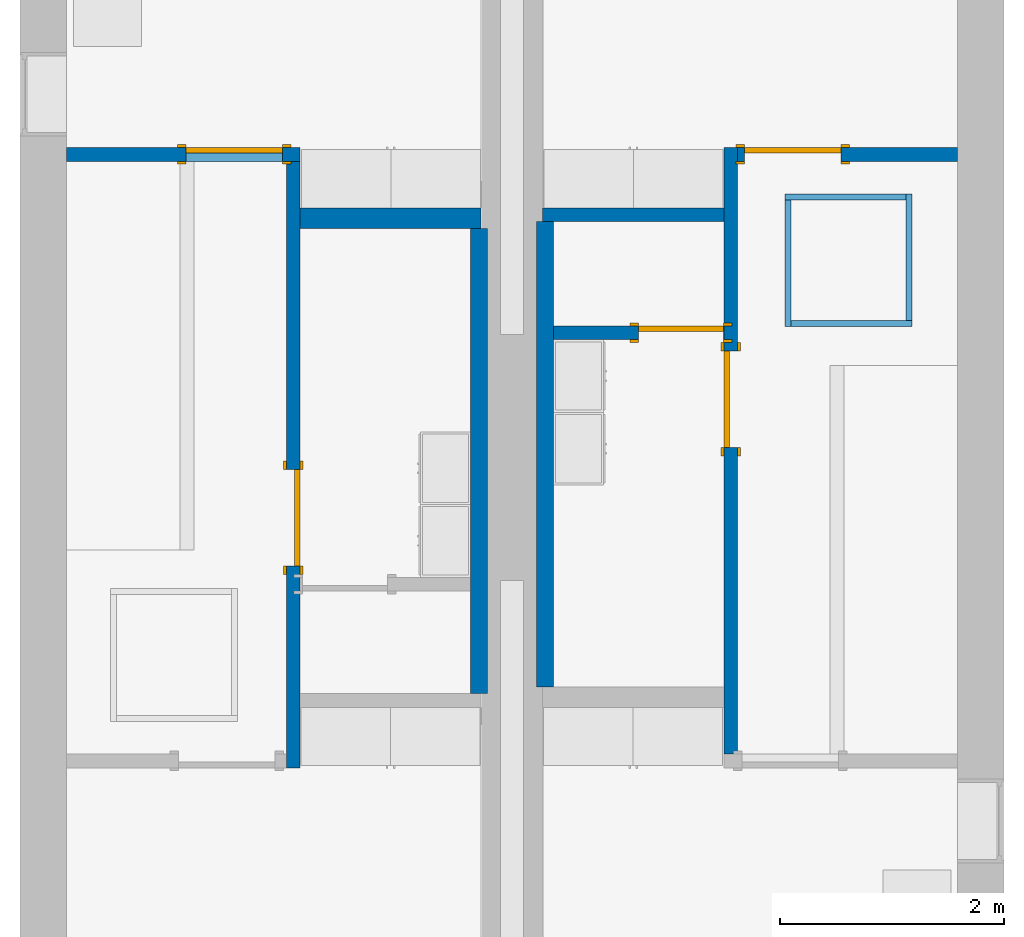
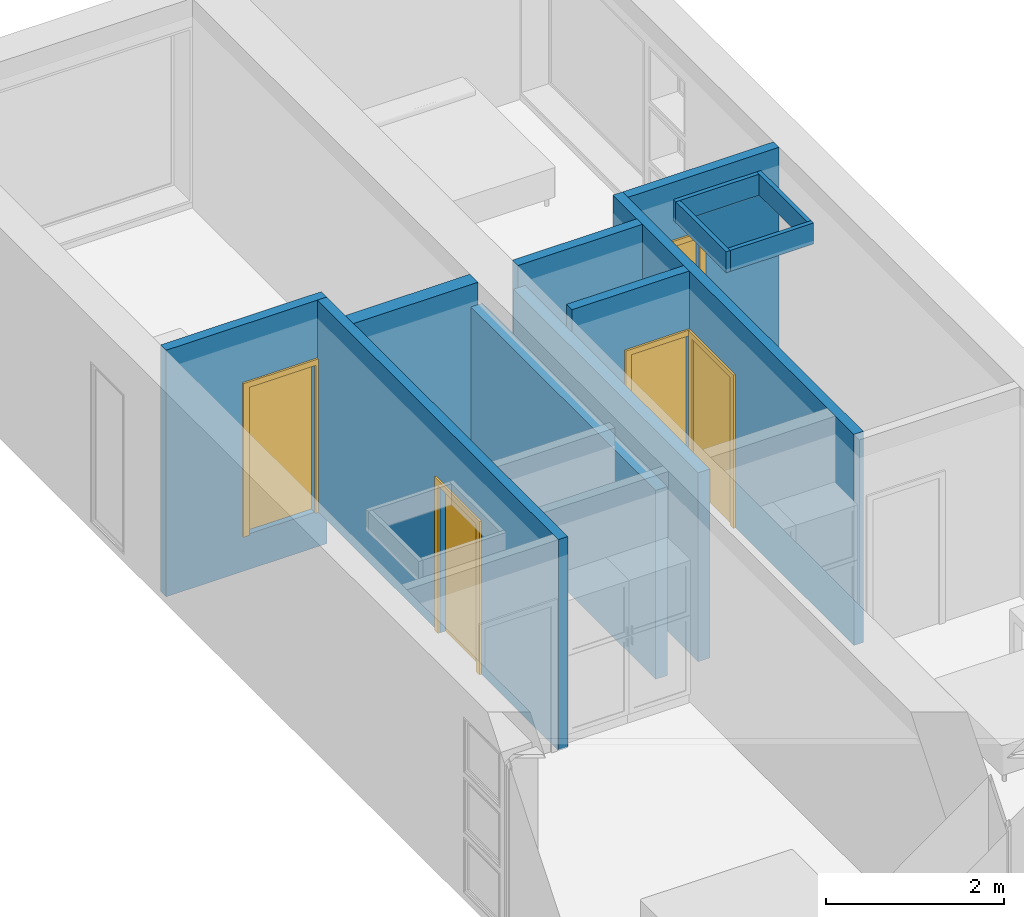
# One storey, part 3 of 10: 13 walls, 5 doors, 6 openings.
"""IFC2X3 building model written with IfcOpenShell, lengths in metres."""

import ifcopenshell
import ifcopenshell.guid

model = None  # the IFC model being written
_history = None  # IfcOwnerHistory: only IFC2X3 demands one
_inside = {}  # id of a spatial element -> (the spatial element, [elements in it])
_under = {}  # id of a project, library or spatial element -> (it, [spatial elements below it])
_declared = {}  # id of a project -> (the project, [libraries it declares])
_typed = {}  # id of a type object -> (the type object, [elements of that type])
_made_of = {}  # id of a material, layer set ... -> (it, [elements and type objects made of it])


def new_model(schema):
    """Start an empty IFC model of exactly this schema.

    Asked for "IFC4X3", IfcOpenShell would pick the latest addendum, in which some entities
    have other attributes; the version numbers below select the first issue.
    IFC2X3 requires an IfcOwnerHistory on every rooted entity: one is made here for all.
    """
    global model, _history
    if schema == "IFC4X3":
        model = ifcopenshell.file(schema_version=(4, 3, 0, 0))
    else:
        model = ifcopenshell.file(schema=schema)
    _inside.clear()
    _under.clear()
    _declared.clear()
    _typed.clear()
    _made_of.clear()
    _history = None
    if model.schema == "IFC2X3":
        org = make("IfcOrganization", Name="unknown")
        user = make(
            "IfcPersonAndOrganization",
            ThePerson=make("IfcPerson", FamilyName="unknown"),
            TheOrganization=org,
        )
        app = make(
            "IfcApplication",
            ApplicationDeveloper=org,
            Version="unknown",
            ApplicationFullName="unknown",
            ApplicationIdentifier="unknown",
        )
        _history = make(
            "IfcOwnerHistory",
            OwningUser=user,
            OwningApplication=app,
            ChangeAction="ADDED",
            CreationDate=0,
        )
    return model


def make(cls, **values):
    """One entity of the class cls with the attributes given. An attribute that is None is left unset."""
    return model.create_entity(
        cls, **{name: value for name, value in values.items() if value is not None}
    )


def entity(cls, *values):
    """Any entity or typed value of the class cls, its attributes in the order of the schema. None: left unset."""
    e = model.create_entity(cls)
    for i, value in enumerate(values):
        if value is not None:
            e[i] = value
    return e


def rooted(cls, **values):
    """An entity with a GlobalId (a new one), such as an element, a storey or a relation."""
    return make(cls, GlobalId=ifcopenshell.guid.new(), OwnerHistory=_history, **values)


def si_unit(unit_type, name, prefix=None):
    """IfcSIUnit, for example si_unit("LENGTHUNIT", "METRE", prefix="MILLI")."""
    return make("IfcSIUnit", UnitType=unit_type, Prefix=prefix, Name=name)


def converted_unit(unit_type, name, factor, base, dimensions=None, offset=None):
    """IfcConversionBasedUnit, such as the inch: factor (a typed value) times the base unit."""
    return make(
        "IfcConversionBasedUnit"
        if offset is None
        else "IfcConversionBasedUnitWithOffset",
        ConversionOffset=offset,
        Dimensions=None
        if dimensions is None
        else entity("IfcDimensionalExponents", *dimensions),
        UnitType=unit_type,
        Name=name,
        ConversionFactor=make(
            "IfcMeasureWithUnit", ValueComponent=factor, UnitComponent=base
        ),
    )


def derived_unit(unit_type, elements):
    """IfcDerivedUnit: a product of units, each with its exponent."""
    return make(
        "IfcDerivedUnit",
        Elements=[
            make("IfcDerivedUnitElement", Unit=unit, Exponent=power)
            for unit, power in elements
        ],
        UnitType=unit_type,
    )


def assignment(units):
    """IfcUnitAssignment: the units of a project."""
    return None if units is None else make("IfcUnitAssignment", Units=units)


def point(xyz):
    """IfcCartesianPoint."""
    return None if xyz is None else make("IfcCartesianPoint", Coordinates=xyz)


def direction(xyz):
    """IfcDirection."""
    return None if xyz is None else make("IfcDirection", DirectionRatios=xyz)


def frame(location, z_axis=None, x_axis=None):
    """IfcAxis2Placement3D, a coordinate frame: its origin and axes. An axis left out is left unset."""
    return make(
        "IfcAxis2Placement3D",
        Location=point(location),
        Axis=direction(z_axis),
        RefDirection=direction(x_axis),
    )


def frame_2d(location, x_axis=None):
    """IfcAxis2Placement2D, a coordinate frame in the plane: its origin and x axis."""
    return make(
        "IfcAxis2Placement2D", Location=point(location), RefDirection=direction(x_axis)
    )


def origin():
    """The frame at (0, 0, 0) with its axes left unset."""
    return frame((0.0, 0.0, 0.0))


def origin_2d_with_axis():
    """The frame at (0, 0) in the plane with the x axis (1, 0) written out."""
    return frame_2d((0.0, 0.0), x_axis=(1.0, 0.0))


def place(relative_to, where):
    """IfcLocalPlacement: puts the frame where relative to a parent placement (None: the world)."""
    return make(
        "IfcLocalPlacement", PlacementRelTo=relative_to, RelativePlacement=where
    )


def context(
    kind, dimensions, precision=None, world=None, true_north=None, identifier=None
):
    """IfcGeometricRepresentationContext, for example the 3D "Model" context."""
    return make(
        "IfcGeometricRepresentationContext",
        ContextIdentifier=identifier,
        ContextType=kind,
        CoordinateSpaceDimension=dimensions,
        Precision=precision,
        WorldCoordinateSystem=world,
        TrueNorth=true_north,
    )


def subcontext(parent, identifier, kind, view, scale=None):
    """IfcGeometricRepresentationSubContext, for example "Body" below "Model"."""
    return make(
        "IfcGeometricRepresentationSubContext",
        ContextIdentifier=identifier,
        ContextType=kind,
        ParentContext=parent,
        TargetScale=scale,
        TargetView=view,
    )


def project(units=None, contexts=None):
    """IfcProject with its units and contexts."""
    return rooted(
        "IfcProject",
        Name="project",
        RepresentationContexts=contexts,
        UnitsInContext=assignment(units),
    )


def spatial(cls, under=None, at=None, **own):
    """A site, building, storey or space (cls), placed at a placement, below another one or the project."""
    s = rooted(cls, ObjectPlacement=at, **own)
    if under is not None:
        _under.setdefault(under.id(), (under, []))[1].append(s)
    return s


def polyline(points):
    """IfcPolyline through the points."""
    return make("IfcPolyline", Points=[point(p) for p in points])


def profile(cls, at=None, kind="AREA", **sizes):
    """A parametric profile (cls). Its sizes go by their IFC names, for example OverallWidth=200.0."""
    return make(cls, ProfileType=kind, Position=at, **sizes)


def rectangle(**sizes):
    """IfcRectangleProfileDef."""
    return profile("IfcRectangleProfileDef", **sizes)


def outline(outer, holes=None, kind="AREA"):
    """IfcArbitraryClosedProfileDef: a profile drawn as a closed curve; with holes, ...WithVoids."""
    if holes is None:
        return make("IfcArbitraryClosedProfileDef", ProfileType=kind, OuterCurve=outer)
    return make(
        "IfcArbitraryProfileDefWithVoids",
        ProfileType=kind,
        OuterCurve=outer,
        InnerCurves=holes,
    )


def extrude(swept, where, along, depth):
    """IfcExtrudedAreaSolid: the profile swept, set in the frame where, extruded along a direction by depth."""
    return make(
        "IfcExtrudedAreaSolid",
        SweptArea=swept,
        Position=where,
        ExtrudedDirection=direction(along),
        Depth=depth,
    )


def shape(context_of_items, identifier, shape_type, items):
    """IfcShapeRepresentation: the items that make up one representation, for example the "Body"."""
    return make(
        "IfcShapeRepresentation",
        ContextOfItems=context_of_items,
        RepresentationIdentifier=identifier,
        RepresentationType=shape_type,
        Items=items,
    )


def source(mapping_origin, context_of_items, identifier, shape_type, items):
    """IfcRepresentationMap: a shape defined once, which mapped items show again and again."""
    return make(
        "IfcRepresentationMap",
        MappingOrigin=mapping_origin,
        MappedRepresentation=shape(context_of_items, identifier, shape_type, items),
    )


def transform(
    local_origin,
    x_axis=None,
    y_axis=None,
    z_axis=None,
    scale=None,
    scale2=None,
    scale3=None,
    uniform=True,
):
    """IfcCartesianTransformationOperator3D, or its non-uniform kind. x_axis, y_axis, z_axis: its Axis1, 2, 3."""
    if uniform:
        return make(
            "IfcCartesianTransformationOperator3D",
            Axis1=direction(x_axis),
            Axis2=direction(y_axis),
            LocalOrigin=point(local_origin),
            Scale=scale,
            Axis3=direction(z_axis),
        )
    return make(
        "IfcCartesianTransformationOperator3DnonUniform",
        Axis1=direction(x_axis),
        Axis2=direction(y_axis),
        LocalOrigin=point(local_origin),
        Scale=scale,
        Axis3=direction(z_axis),
        Scale2=scale2,
        Scale3=scale3,
    )


def mapped(mapping_source, mapping_target):
    """IfcMappedItem: shows the shape of a source again, moved by a transform."""
    return make(
        "IfcMappedItem", MappingSource=mapping_source, MappingTarget=mapping_target
    )


def material(Name=None, Category=None):
    """IfcMaterial."""
    return make("IfcMaterial", Name=Name, Category=Category)


def material_list(materials):
    """IfcMaterialList."""
    return make("IfcMaterialList", Materials=materials)


def layer(
    of_material, thickness, ventilated=None, Name=None, Category=None, Priority=None
):
    """IfcMaterialLayer: one layer of a wall or slab, of a material (None: an air gap)."""
    return make(
        "IfcMaterialLayer",
        Material=of_material,
        LayerThickness=thickness,
        IsVentilated=ventilated,
        Name=Name,
        Category=Category,
        Priority=Priority,
    )


def layer_set(layers, Name=None):
    """IfcMaterialLayerSet."""
    return make("IfcMaterialLayerSet", MaterialLayers=layers, LayerSetName=Name)


def layer_usage(for_layer_set, set_direction, sense, offset, extent=None):
    """IfcMaterialLayerSetUsage: how a layer set lies in its element."""
    return make(
        "IfcMaterialLayerSetUsage",
        ForLayerSet=for_layer_set,
        LayerSetDirection=set_direction,
        DirectionSense=sense,
        OffsetFromReferenceLine=offset,
        ReferenceExtent=extent,
    )


def made_of(thing, what):
    """Note that an element or type object is made of a material, layer set ...; save() writes the relation."""
    if what is not None:
        _made_of.setdefault(what.id(), (what, []))[1].append(thing)
    return thing


def type_object(cls, material=None, **own):
    """A type object (cls), such as IfcWallType, which elements share."""
    return made_of(rooted(cls, **own), material)


def type_shapes(of_type, sources):
    """Give a type object the sources (RepresentationMaps) that its elements show as mapped items."""
    of_type.RepresentationMaps = sources


def element(
    cls,
    number,
    at=None,
    inside=None,
    cuts=None,
    type_object=None,
    material=None,
    context=None,
    identifier="Body",
    shape_type=None,
    held_by="IfcProductDefinitionShape",
    body=None,
    shapes=None,
    **own,
):
    """One element of the class cls, such as IfcWall. Its Tag is "e" and its number.

    at: its placement. inside: the storey or other place that contains it. cuts: it is an
    opening in that element (IfcRelVoidsElement). A single representation is given by context,
    identifier, shape_type and body (its items); several are given by shapes. held_by: the class
    of the entity that holds the representations. save() writes the other relations.
    """
    e = rooted(cls, Tag="e%d" % number, ObjectPlacement=at, **own)
    if body is not None:
        shapes = [shape(context, identifier, shape_type, body)]
    if shapes is not None:
        e.Representation = make(held_by, Representations=shapes)
    if inside is not None:
        _inside.setdefault(inside.id(), (inside, []))[1].append(e)
    if cuts is not None:
        rooted(
            "IfcRelVoidsElement", RelatingBuildingElement=cuts, RelatedOpeningElement=e
        )
    if type_object is not None:
        _typed.setdefault(type_object.id(), (type_object, []))[1].append(e)
    return made_of(e, material)


def fill(opening, filler):
    """IfcRelFillsElement: the door or window that sits in an opening."""
    return rooted(
        "IfcRelFillsElement",
        RelatingOpeningElement=opening,
        RelatedBuildingElement=filler,
    )


def aggregate(whole, parts):
    """IfcRelAggregates: a whole, such as a stair, and the parts it consists of."""
    return rooted("IfcRelAggregates", RelatingObject=whole, RelatedObjects=parts)


def save(model, path):
    """Write the relations noted so far, then the file.

    IfcRelAggregates (storeys below a building ...), IfcRelContainedInSpatialStructure (elements
    in a storey), IfcRelDefinesByType, IfcRelAssociatesMaterial and IfcRelDeclares: one each for
    every whole, place, type object, material and project.
    """
    for whole, parts in _under.values():
        aggregate(whole, parts)
    for where, things in _inside.values():
        rooted(
            "IfcRelContainedInSpatialStructure",
            RelatedElements=things,
            RelatingStructure=where,
        )
    for kind, things in _typed.values():
        rooted("IfcRelDefinesByType", RelatedObjects=things, RelatingType=kind)
    for what, things in _made_of.values():
        rooted("IfcRelAssociatesMaterial", RelatedObjects=things, RelatingMaterial=what)
    for by, libraries in _declared.values():
        rooted("IfcRelDeclares", RelatingContext=by, RelatedDefinitions=libraries)
    model.write(path)


model = new_model("IFC2X3")

# Units and contexts
model_context = context("Model", 3, precision=1e-05, world=origin(), true_north=direction((6.12303176911189e-17, 1.0)))
body_context = subcontext(model_context, "Body", "Model", "MODEL_VIEW")
ifc_project = project(units=[derived_unit("USERDEFINED", [(si_unit("LENGTHUNIT", "METRE"), -2), (si_unit("TIMEUNIT", "SECOND"), -2), (si_unit("MASSUNIT", "GRAM", prefix="KILO"), 1)]), si_unit("FREQUENCYUNIT", "HERTZ"), si_unit("LENGTHUNIT", "METRE"), si_unit("ILLUMINANCEUNIT", "LUX"), derived_unit("LINEARVELOCITYUNIT", [(si_unit("TIMEUNIT", "SECOND"), -1), (si_unit("LENGTHUNIT", "METRE"), 1)]), si_unit("POWERUNIT", "WATT"), si_unit("LUMINOUSINTENSITYUNIT", "CANDELA"), si_unit("AREAUNIT", "SQUARE_METRE"), si_unit("VOLUMEUNIT", "CUBIC_METRE"), si_unit("ELECTRICVOLTAGEUNIT", "VOLT"), si_unit("PRESSUREUNIT", "PASCAL"), converted_unit("PLANEANGLEUNIT", "DEGREE", entity("IfcRatioMeasure", 0.0174532925199433), si_unit("PLANEANGLEUNIT", "RADIAN"), dimensions=[0, 0, 0, 0, 0, 0, 0]), si_unit("THERMODYNAMICTEMPERATUREUNIT", "DEGREE_CELSIUS"), si_unit("MASSUNIT", "GRAM", prefix="KILO"), derived_unit("VOLUMETRICFLOWRATEUNIT", [(si_unit("LENGTHUNIT", "METRE"), 3), (si_unit("TIMEUNIT", "SECOND"), -1)]), si_unit("TIMEUNIT", "SECOND"), si_unit("LUMINOUSFLUXUNIT", "LUMEN"), derived_unit("USERDEFINED", [(si_unit("LUMINOUSFLUXUNIT", "LUMEN"), 1), (si_unit("TIMEUNIT", "SECOND"), 3), (si_unit("MASSUNIT", "GRAM", prefix="KILO"), -1), (si_unit("LENGTHUNIT", "METRE"), -2)]), si_unit("FORCEUNIT", "NEWTON", prefix="KILO"), si_unit("ELECTRICCURRENTUNIT", "AMPERE"), derived_unit("THERMALTRANSMITTANCEUNIT", [(si_unit("TIMEUNIT", "SECOND"), -3), (si_unit("THERMODYNAMICTEMPERATUREUNIT", "KELVIN"), -1), (si_unit("MASSUNIT", "GRAM", prefix="KILO"), 1)])], contexts=[model_context])

# Site, building, storey
site_placement = place(None, origin())
site = spatial("IfcSite", under=ifc_project, at=site_placement, CompositionType="ELEMENT")
building_placement = place(site_placement, origin())
building = spatial("IfcBuilding", under=site, at=building_placement, CompositionType="ELEMENT")
storey_placement = place(building_placement, frame((0.0, 0.0, 3.10000000000038)))
storey = spatial("IfcBuildingStorey", under=building, at=storey_placement, Name="Level 2", CompositionType="ELEMENT", Elevation=3.10000000000038)

# Wall, opening, door
ifc_material_1 = material(Name="Plasterboard")
ifc_layer_1 = layer(ifc_material_1, 0.016)
ifc_material_2 = material(Name="Metal - Stud Layer")
ifc_layer_2 = layer(ifc_material_2, 0.092)
ifc_layer_3 = layer(ifc_material_1, 0.016)
ifc_layer_set_1 = layer_set([ifc_layer_1, ifc_layer_2, ifc_layer_3], Name="Mur de base:Interior - Partition (92mm Stud)")
ifc_layer_usage_1 = layer_usage(ifc_layer_set_1, "AXIS2", "NEGATIVE", 0.062)
wall_type_1 = type_object("IfcWallType", Name="Mur de base:Interior - Partition (92mm Stud)", PredefinedType="STANDARD", material=ifc_layer_set_1)
wall_1_placement = place(storey_placement, frame((0.416999999999999, -6.188, -0.488000000000377)))
wall_1 = element("IfcWallStandardCase", 1, at=wall_1_placement, inside=storey, type_object=wall_type_1, material=ifc_layer_usage_1, Name="Mur de base:Interior - Partition (92mm Stud)", ObjectType="Mur de base:Interior - Partition (92mm Stud)", context=body_context, shape_type="SweptSolid", body=[
    extrude(rectangle(XDim=2.089, YDim=0.124, at=frame_2d((1.0445, 6.24500451351651e-17), x_axis=(-1.0, 0.0))), origin(), (0.0, 0.0, 1.0), 3.38800000000021),
])
opening_1_placement = place(wall_1_placement, frame((1.06629999999999, -0.0620000000000032, 0.488000000000196)))
opening_1 = element("IfcOpeningElement", 2, at=opening_1_placement, cuts=wall_1, Name="M_Single-Flush:0864 x 2032mm:1", ObjectType="Opening", context=body_context, shape_type="SweptSolid", body=[
    extrude(rectangle(XDim=0.864, YDim=2.032, at=frame_2d((1.016, 0.432), x_axis=(0.0, 1.0))), frame((0.0, 0.0, 0.0), z_axis=(0.0, 1.0, 0.0), x_axis=(0.0, 0.0, 1.0)), (0.0, 0.0, 1.0), 0.124),
])
ifc_material_3 = material(Name="Door - Frame")
ifc_material_4 = material(Name="Door - Panel")
ifc_material_list_1 = material_list([ifc_material_3, ifc_material_4])
ifc_material_list_2 = material_list([ifc_material_3, ifc_material_4])
door_style_1 = type_object("IfcDoorStyle", Name="0864 x 2032mm", ConstructionType="USERDEFINED", OperationType="SINGLE_SWING_RIGHT", ParameterTakesPrecedence=False, Sizeable=False, material=ifc_material_list_2)
shared_shape_1 = source(origin(), body_context, "Body", "SweptSolid", [
    extrude(outline(polyline([(-0.508, -1.073), (0.508, -1.073), (0.508, 1.035), (0.432, 1.035), (0.432, -0.997000000000002), (-0.432, -0.997000000000002), (-0.432, 1.035), (-0.508, 1.035), (-0.508, -1.073)])), frame((0.432000000000001, 0.123999999999999, 1.035), z_axis=(0.0, 1.0, 0.0), x_axis=(1.0, 0.0, 0.0)), (0.0, 0.0, 1.0), 0.0249999999999944),
    extrude(outline(polyline([(-1.073, -0.507999999999997), (1.035, -0.507999999999997), (1.035, -0.432000000000007), (-0.997, -0.432000000000007), (-0.997, 0.432000000000002), (1.035, 0.432000000000002), (1.035, 0.508000000000003), (-1.073, 0.508000000000003), (-1.073, -0.507999999999997)])), frame((0.432000000000003, -0.0250000000000064, 1.035), z_axis=(0.0, 1.0, 0.0), x_axis=(0.0, 0.0, -1.0)), (0.0, 0.0, 1.0), 0.0250000000000056),
    extrude(rectangle(XDim=0.051, YDim=0.864, at=origin_2d_with_axis()), frame((0.432, 0.0984999999999992, 0.0), z_axis=(0.0, 0.0, 1.0), x_axis=(0.0, 1.0, 0.0)), (0.0, 0.0, 1.0), 2.032),
])
type_shapes(door_style_1, [shared_shape_1])
door_1_placement = place(opening_1_placement, origin())
door_1 = element("IfcDoor", 3, at=door_1_placement, inside=storey, type_object=door_style_1, material=ifc_material_list_1, Name="M_Single-Flush:0864 x 2032mm", ObjectType="0864 x 2032mm", OverallHeight=2.032, OverallWidth=0.864, context=body_context, shape_type="MappedRepresentation", body=[
    mapped(shared_shape_1, transform((0.0, 0.0, 0.0), scale=1.0)),
])
fill(opening_1, door_1)

ifc_layer_usage_2 = layer_usage(ifc_layer_set_1, "AXIS2", "NEGATIVE", 0.062)
wall_2_placement = place(storey_placement, frame((2.444, -6.25000000000001, 0.0), z_axis=(0.0, 0.0, 1.0), x_axis=(0.0, -1.0, 0.0)))
wall_2 = element("IfcWallStandardCase", 4, at=wall_2_placement, inside=storey, type_object=wall_type_1, material=ifc_layer_usage_2, Name="Mur de base:Interior - Partition (92mm Stud)", ObjectType="Mur de base:Interior - Partition (92mm Stud)", context=body_context, shape_type="SweptSolid", body=[
    extrude(rectangle(XDim=5.424, YDim=0.124, at=frame_2d((2.712, 1.00613961606655e-16), x_axis=(-1.0, 0.0))), origin(), (0.0, 0.0, 1.0), 2.90000000000001),
])
opening_2_placement = place(wall_2_placement, frame((2.75605117851058, -0.0620000000000057, 0.0)))
opening_2 = element("IfcOpeningElement", 5, at=opening_2_placement, cuts=wall_2, Name="M_Single-Flush:0864 x 2032mm:1", ObjectType="Opening", context=body_context, shape_type="SweptSolid", body=[
    extrude(rectangle(XDim=0.863999999999999, YDim=2.032, at=frame_2d((1.016, 0.431999999999999), x_axis=(0.0, 1.0))), frame((0.0, 0.0, 0.0), z_axis=(0.0, 1.0, 0.0), x_axis=(0.0, 0.0, 1.0)), (0.0, 0.0, 1.0), 0.124),
])
ifc_material_list_3 = material_list([ifc_material_3, ifc_material_4])
door_2_placement = place(opening_2_placement, origin())
door_2 = element("IfcDoor", 6, at=door_2_placement, inside=storey, type_object=door_style_1, material=ifc_material_list_3, Name="M_Single-Flush:0864 x 2032mm", ObjectType="0864 x 2032mm", OverallHeight=2.032, OverallWidth=0.864000000000001, context=body_context, shape_type="MappedRepresentation", body=[
    mapped(shared_shape_1, transform((0.0, 0.0, 0.0), scale=1.0)),
])
fill(opening_2, door_2)

# Wall, openings, door
ifc_layer_usage_3 = layer_usage(ifc_layer_set_1, "AXIS2", "NEGATIVE", 0.062)
wall_3_placement = place(storey_placement, frame((6.356, -11.55, 0.0), z_axis=(0.0, 0.0, 1.0), x_axis=(0.0, 1.0, 0.0)))
wall_3 = element("IfcWallStandardCase", 7, at=wall_3_placement, inside=storey, type_object=wall_type_1, material=ifc_layer_usage_3, Name="Mur de base:Interior - Partition (92mm Stud)", ObjectType="Mur de base:Interior - Partition (92mm Stud)", context=body_context, shape_type="SweptSolid", body=[
    extrude(rectangle(XDim=5.424, YDim=0.124, at=frame_2d((2.712, 1.00613961606655e-16), x_axis=(-1.0, 0.0))), origin(), (0.0, 0.0, 1.0), 2.90000000000001),
])
opening_3_placement = place(wall_3_placement, origin())
element("IfcOpeningElement", 8, at=opening_3_placement, cuts=wall_3, Name="Mur de base:Interior - Partition (92mm Stud)", ObjectType="Opening", context=body_context, shape_type="SweptSolid", body=[
    extrude(rectangle(XDim=2.032, YDim=0.124, at=frame_2d((0.0, 0.0), x_axis=(0.0, 1.0))), frame((3.76661576492847, 0.0626250000000023, 1.016), z_axis=(0.0, 1.0, 0.0), x_axis=(1.0, 0.0, 0.0)), (0.0, 0.0, 1.0), 0.761999999999999),
])
opening_4_placement = place(wall_3_placement, frame((2.74061576492847, -0.0620000000000056, 0.0)))
opening_4 = element("IfcOpeningElement", 9, at=opening_4_placement, cuts=wall_3, Name="M_Single-Flush:0864 x 2032mm:1", ObjectType="Opening", context=body_context, shape_type="SweptSolid", body=[
    extrude(rectangle(XDim=0.863999999999999, YDim=2.032, at=frame_2d((1.016, 0.432), x_axis=(0.0, 1.0))), frame((0.0, 0.0, 0.0), z_axis=(0.0, 1.0, 0.0), x_axis=(0.0, 0.0, 1.0)), (0.0, 0.0, 1.0), 0.124),
])
ifc_material_list_4 = material_list([ifc_material_3, ifc_material_4])
door_3_placement = place(opening_4_placement, origin())
door_3 = element("IfcDoor", 10, at=door_3_placement, inside=storey, type_object=door_style_1, material=ifc_material_list_4, Name="M_Single-Flush:0864 x 2032mm", ObjectType="0864 x 2032mm", OverallHeight=2.032, OverallWidth=0.864, context=body_context, shape_type="MappedRepresentation", body=[
    mapped(shared_shape_1, transform((0.0, 0.0, 0.0), scale=1.0)),
])
fill(opening_4, door_3)

# Wall, opening, door
ifc_layer_usage_4 = layer_usage(ifc_layer_set_1, "AXIS2", "NEGATIVE", 0.062)
wall_4_placement = place(storey_placement, frame((6.41800000000001, -6.188, 0.0)))
wall_4 = element("IfcWallStandardCase", 11, at=wall_4_placement, inside=storey, type_object=wall_type_1, material=ifc_layer_usage_4, Name="Mur de base:Interior - Partition (92mm Stud)", ObjectType="Mur de base:Interior - Partition (92mm Stud)", context=body_context, shape_type="SweptSolid", body=[
    extrude(rectangle(XDim=1.96499999999998, YDim=0.124, at=frame_2d((0.982499999999991, -1.35308431126191e-16), x_axis=(-1.0, 0.0))), origin(), (0.0, 0.0, 1.0), 2.90000000000001),
])
opening_5_placement = place(wall_4_placement, frame((0.0600000000000002, -0.0620000000000021, 0.0)))
opening_5 = element("IfcOpeningElement", 12, at=opening_5_placement, cuts=wall_4, Name="M_Single-Flush:0864 x 2032mm:1", ObjectType="Opening", context=body_context, shape_type="SweptSolid", body=[
    extrude(rectangle(XDim=0.864, YDim=2.032, at=frame_2d((1.016, 0.432), x_axis=(0.0, -1.0))), frame((0.0, 0.0, 0.0), z_axis=(0.0, 1.0, 0.0), x_axis=(0.0, 0.0, 1.0)), (0.0, 0.0, 1.0), 0.124),
])
ifc_material_list_5 = material_list([ifc_material_3, ifc_material_4])
ifc_material_list_6 = material_list([ifc_material_3, ifc_material_4])
door_style_2 = type_object("IfcDoorStyle", Name="0864 x 2032mm", ConstructionType="USERDEFINED", OperationType="SINGLE_SWING_LEFT", ParameterTakesPrecedence=False, Sizeable=False, material=ifc_material_list_6)
shared_shape_2 = source(origin(), body_context, "Body", "SweptSolid", [
    extrude(outline(polyline([(-0.508, -1.073), (0.508, -1.073), (0.508, 1.035), (0.432, 1.035), (0.432, -0.997000000000002), (-0.432, -0.997000000000002), (-0.432, 1.035), (-0.508, 1.035), (-0.508, -1.073)])), frame((0.432, 0.148999999999988, 1.035), z_axis=(0.0, -1.0, 0.0), x_axis=(-1.0, 0.0, 0.0)), (0.0, 0.0, 1.0), 0.0249999999999944),
    extrude(outline(polyline([(-1.073, -0.507999999999997), (1.035, -0.507999999999997), (1.035, -0.432000000000007), (-0.997, -0.432000000000007), (-0.997, 0.432000000000002), (1.035, 0.432000000000002), (1.035, 0.508000000000003), (-1.073, 0.508000000000003), (-1.073, -0.507999999999997)])), frame((0.431999999999998, 0.0, 1.035), z_axis=(0.0, -1.0, 0.0), x_axis=(0.0, 0.0, -1.0)), (0.0, 0.0, 1.0), 0.0250000000000056),
    extrude(rectangle(XDim=0.864, YDim=0.051, at=frame_2d((0.0, 3.46944695195361e-18), x_axis=(1.0, 0.0))), frame((0.432, 0.0984999999999937, 0.0)), (0.0, 0.0, 1.0), 2.032),
])
type_shapes(door_style_2, [shared_shape_2])
door_4_placement = place(opening_5_placement, origin())
door_4 = element("IfcDoor", 13, at=door_4_placement, inside=storey, type_object=door_style_2, material=ifc_material_list_5, Name="M_Single-Flush:0864 x 2032mm", ObjectType="0864 x 2032mm", OverallHeight=2.032, OverallWidth=0.864, context=body_context, shape_type="MappedRepresentation", body=[
    mapped(shared_shape_2, transform((0.0, 0.0, 0.0), scale=1.0)),
])
fill(opening_5, door_4)

# Wall
ifc_layer_usage_5 = layer_usage(ifc_layer_set_1, "AXIS2", "NEGATIVE", 0.062)
wall_5_placement = place(storey_placement, frame((4.67499999999999, -6.728, 0.0)))
element("IfcWallStandardCase", 14, at=wall_5_placement, inside=storey, type_object=wall_type_1, material=ifc_layer_usage_5, Name="Mur de base:Interior - Partition (92mm Stud)", ObjectType="Mur de base:Interior - Partition (92mm Stud)", context=body_context, shape_type="SweptSolid", body=[
    extrude(rectangle(XDim=1.61900000000002, YDim=0.124, at=frame_2d((0.809500000000009, -3.81639164714898e-17), x_axis=(-1.0, 0.0))), origin(), (0.0, 0.0, 1.0), 2.90000000000001),
])

# Wall, opening, door
ifc_layer_usage_6 = layer_usage(ifc_layer_set_1, "AXIS2", "POSITIVE", -0.062)
wall_6_placement = place(storey_placement, frame((4.76999999999999, -7.78338423507152, 0.0)))
wall_6 = element("IfcWallStandardCase", 15, at=wall_6_placement, inside=storey, type_object=wall_type_1, material=ifc_layer_usage_6, Name="Mur de base:Interior - Partition (92mm Stud)", ObjectType="Mur de base:Interior - Partition (92mm Stud)", context=body_context, shape_type="SweptSolid", body=[
    extrude(rectangle(XDim=1.52400000000002, YDim=0.124, at=frame_2d((0.762000000000009, 0.0), x_axis=(-1.0, 0.0))), origin(), (0.0, 0.0, 1.0), 2.90000000000001),
])
opening_6_placement = place(wall_6_placement, frame((0.761375000000016, -0.0620000000000032, 0.0)))
opening_6 = element("IfcOpeningElement", 16, at=opening_6_placement, cuts=wall_6, Name="M_Single-Flush:0762 x 2032mm:1", ObjectType="Opening", context=body_context, shape_type="SweptSolid", body=[
    extrude(rectangle(XDim=0.762, YDim=2.032, at=frame_2d((1.016, 0.381), x_axis=(0.0, 1.0))), frame((0.0, 0.0, 0.0), z_axis=(0.0, 1.0, 0.0), x_axis=(0.0, 0.0, 1.0)), (0.0, 0.0, 1.0), 0.124),
])
ifc_material_list_7 = material_list([ifc_material_3, ifc_material_4])
ifc_material_list_8 = material_list([ifc_material_3, ifc_material_4])
door_style_3 = type_object("IfcDoorStyle", Name="0762 x 2032mm", ConstructionType="USERDEFINED", OperationType="SINGLE_SWING_RIGHT", ParameterTakesPrecedence=False, Sizeable=False, material=ifc_material_list_8)
shared_shape_3 = source(origin(), body_context, "Body", "SweptSolid", [
    extrude(outline(polyline([(-0.457, -1.073), (0.457, -1.073), (0.457, 1.035), (0.381, 1.035), (0.381, -0.997000000000002), (-0.381, -0.997000000000002), (-0.381, 1.035), (-0.457, 1.035), (-0.457, -1.073)])), frame((0.381000000000001, 0.123999999999999, 1.035), z_axis=(0.0, 1.0, 0.0), x_axis=(1.0, 0.0, 0.0)), (0.0, 0.0, 1.0), 0.0249999999999945),
    extrude(outline(polyline([(-1.073, -0.456999999999997), (1.035, -0.456999999999997), (1.035, -0.381000000000007), (-0.997, -0.381000000000007), (-0.997, 0.381000000000002), (1.035, 0.381000000000002), (1.035, 0.457000000000003), (-1.073, 0.457000000000003), (-1.073, -0.456999999999997)])), frame((0.381000000000003, -0.0250000000000063, 1.035), z_axis=(0.0, 1.0, 0.0), x_axis=(0.0, 0.0, -1.0)), (0.0, 0.0, 1.0), 0.0250000000000056),
    extrude(rectangle(XDim=0.051, YDim=0.762, at=origin_2d_with_axis()), frame((0.381, 0.0984999999999993, 0.0), z_axis=(0.0, 0.0, 1.0), x_axis=(0.0, 1.0, 0.0)), (0.0, 0.0, 1.0), 2.032),
])
type_shapes(door_style_3, [shared_shape_3])
door_5_placement = place(opening_6_placement, origin())
door_5 = element("IfcDoor", 17, at=door_5_placement, inside=storey, type_object=door_style_3, material=ifc_material_list_7, Name="M_Single-Flush:0762 x 2032mm", ObjectType="0762 x 2032mm", OverallHeight=2.032, OverallWidth=0.762, context=body_context, shape_type="MappedRepresentation", body=[
    mapped(shared_shape_3, transform((0.0, 0.0, 0.0), scale=1.0)),
])
fill(opening_6, door_5)

# Walls
ifc_layer_4 = layer(ifc_material_1, 0.016)
ifc_layer_5 = layer(ifc_material_2, 0.152)
ifc_layer_6 = layer(ifc_material_1, 0.016)
ifc_layer_set_2 = layer_set([ifc_layer_4, ifc_layer_5, ifc_layer_6], Name="Mur de base:Interior - Plumbing (152mm Stud)")
ifc_layer_usage_7 = layer_usage(ifc_layer_set_2, "AXIS2", "NEGATIVE", 0.092)
wall_type_2 = type_object("IfcWallType", Name="Mur de base:Interior - Plumbing (152mm Stud)", PredefinedType="STANDARD", material=ifc_layer_set_2)
wall_7_placement = place(storey_placement, frame((2.506, -6.758, 0.0)))
element("IfcWallStandardCase", 18, at=wall_7_placement, inside=storey, type_object=wall_type_2, material=ifc_layer_usage_7, Name="Mur de base:Interior - Plumbing (152mm Stud)", ObjectType="Mur de base:Interior - Plumbing (152mm Stud)", context=body_context, shape_type="SweptSolid", body=[
    extrude(rectangle(XDim=1.61899999999999, YDim=0.183999999999999, at=frame_2d((0.809499999999996, 3.05311331771918e-16), x_axis=(-1.0, 0.0))), origin(), (0.0, 0.0, 1.0), 2.90000000000001),
])
ifc_layer_7 = layer(ifc_material_2, 0.136)
ifc_layer_8 = layer(ifc_material_1, 0.016)
ifc_layer_set_3 = layer_set([ifc_layer_7, ifc_layer_8], Name="Mur de base:Interior - Furring (152 mm Stud)")
ifc_layer_usage_8 = layer_usage(ifc_layer_set_3, "AXIS2", "POSITIVE", -0.076)
wall_type_3 = type_object("IfcWallType", Name="Mur de base:Interior - Furring (152 mm Stud)", PredefinedType="STANDARD", material=ifc_layer_set_3)
wall_8_placement = place(storey_placement, frame((4.69399999999999, -6.79, 0.0), z_axis=(0.0, 0.0, 1.0), x_axis=(0.0, -1.0, 0.0)))
element("IfcWallStandardCase", 19, at=wall_8_placement, inside=storey, type_object=wall_type_3, material=ifc_layer_usage_8, Name="Mur de base:Interior - Furring (152 mm Stud)", ObjectType="Mur de base:Interior - Furring (152 mm Stud)", context=body_context, shape_type="SweptSolid", body=[
    extrude(rectangle(XDim=4.16000000000001, YDim=0.152, at=frame_2d((2.08, 2.08166817117217e-17), x_axis=(-1.0, 0.0))), origin(), (0.0, 0.0, 1.0), 2.59500000000001),
])
ifc_layer_usage_9 = layer_usage(ifc_layer_set_3, "AXIS2", "POSITIVE", -0.076)
wall_9_placement = place(storey_placement, frame((4.10599999999998, -11.01, 0.0), z_axis=(0.0, 0.0, 1.0), x_axis=(0.0, 1.0, 0.0)))
element("IfcWallStandardCase", 20, at=wall_9_placement, inside=storey, type_object=wall_type_3, material=ifc_layer_usage_9, Name="Mur de base:Interior - Furring (152 mm Stud)", ObjectType="Mur de base:Interior - Furring (152 mm Stud)", context=body_context, shape_type="SweptSolid", body=[
    extrude(rectangle(XDim=4.16, YDim=0.152, at=frame_2d((2.08, -4.16333634234434e-17), x_axis=(-1.0, 0.0))), origin(), (0.0, 0.0, 1.0), 2.59500000000001),
])
ifc_layer_9 = layer(ifc_material_2, 0.038)
ifc_layer_10 = layer(ifc_material_1, 0.016)
ifc_layer_set_4 = layer_set([ifc_layer_9, ifc_layer_10], Name="Mur de base:Interior - Furring (38 mm Stud)")
ifc_layer_usage_10 = layer_usage(ifc_layer_set_4, "AXIS2", "NEGATIVE", 0.027)
wall_type_4 = type_object("IfcWallType", Name="Mur de base:Interior - Furring (38 mm Stud)", PredefinedType="STANDARD", material=ifc_layer_set_4)
wall_10_placement = place(storey_placement, frame((6.84045000000003, -6.56745000000005, 2.612)))
element("IfcWallStandardCase", 21, at=wall_10_placement, inside=storey, type_object=wall_type_4, material=ifc_layer_usage_10, Name="Mur de base:Interior - Furring (38 mm Stud)", ObjectType="Mur de base:Interior - Furring (38 mm Stud)", context=body_context, shape_type="SweptSolid", body=[
    extrude(rectangle(XDim=1.0831, YDim=0.0540000000000007, at=frame_2d((0.54155, 0.0), x_axis=(-1.0, 0.0))), origin(), (0.0, 0.0, 1.0), 0.288000000000013),
])
ifc_layer_usage_11 = layer_usage(ifc_layer_set_4, "AXIS2", "NEGATIVE", 0.027)
wall_11_placement = place(storey_placement, frame((6.86745000000003, -7.72955000000001, 2.612), z_axis=(0.0, 0.0, 1.0), x_axis=(0.0, 1.0, 0.0)))
element("IfcWallStandardCase", 22, at=wall_11_placement, inside=storey, type_object=wall_type_4, material=ifc_layer_usage_11, Name="Mur de base:Interior - Furring (38 mm Stud)", ObjectType="Mur de base:Interior - Furring (38 mm Stud)", context=body_context, shape_type="SweptSolid", body=[
    extrude(rectangle(XDim=1.13509999999996, YDim=0.0540000000000007, at=frame_2d((0.567549999999979, 0.0), x_axis=(-1.0, 0.0))), origin(), (0.0, 0.0, 1.0), 0.288000000000013),
])
ifc_layer_usage_12 = layer_usage(ifc_layer_set_4, "AXIS2", "NEGATIVE", 0.027)
wall_12_placement = place(storey_placement, frame((7.97755000000003, -7.70255000000001, 2.612), z_axis=(0.0, 0.0, 1.0), x_axis=(-1.0, 0.0, 0.0)))
element("IfcWallStandardCase", 23, at=wall_12_placement, inside=storey, type_object=wall_type_4, material=ifc_layer_usage_12, Name="Mur de base:Interior - Furring (38 mm Stud)", ObjectType="Mur de base:Interior - Furring (38 mm Stud)", context=body_context, shape_type="SweptSolid", body=[
    extrude(rectangle(XDim=1.0831, YDim=0.0540000000000007, at=frame_2d((0.54155, -6.59194920871187e-17), x_axis=(-1.0, 0.0))), origin(), (0.0, 0.0, 1.0), 0.288000000000013),
])
ifc_layer_usage_13 = layer_usage(ifc_layer_set_4, "AXIS2", "NEGATIVE", 0.027)
wall_13_placement = place(storey_placement, frame((7.95055000000003, -6.54045000000005, 2.612), z_axis=(0.0, 0.0, 1.0), x_axis=(0.0, -1.0, 0.0)))
element("IfcWallStandardCase", 24, at=wall_13_placement, inside=storey, type_object=wall_type_4, material=ifc_layer_usage_13, Name="Mur de base:Interior - Furring (38 mm Stud)", ObjectType="Mur de base:Interior - Furring (38 mm Stud)", context=body_context, shape_type="SweptSolid", body=[
    extrude(rectangle(XDim=1.13509999999996, YDim=0.0540000000000007, at=frame_2d((0.56754999999998, 0.0), x_axis=(-1.0, 0.0))), origin(), (0.0, 0.0, 1.0), 0.288000000000013),
])

save(model, "model.ifc")
